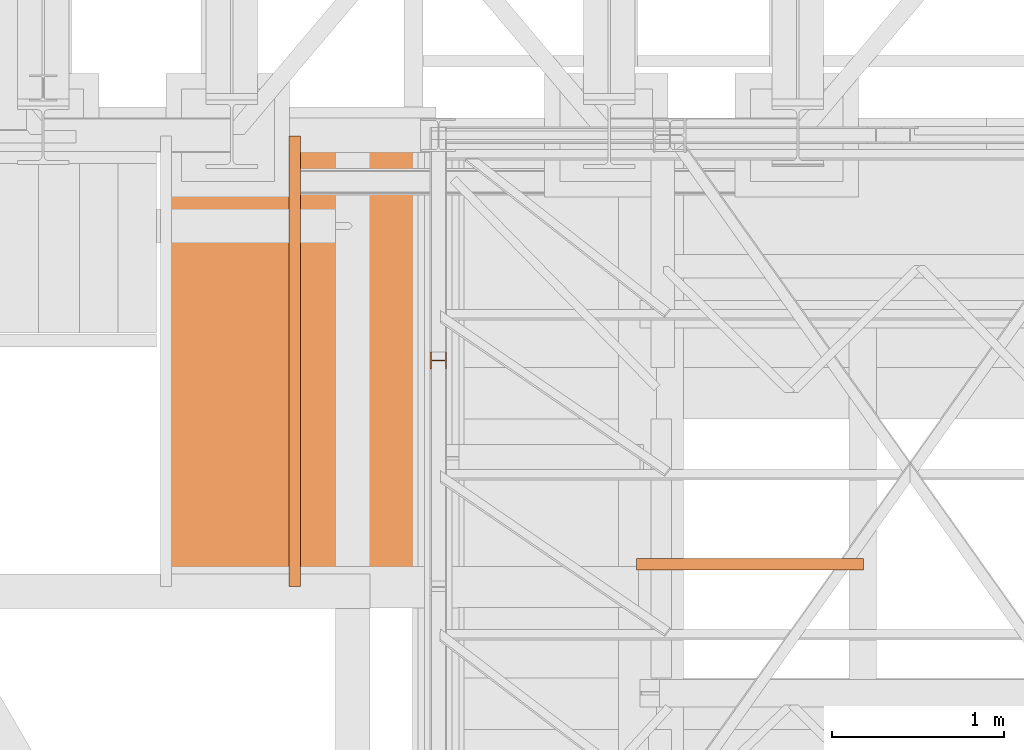
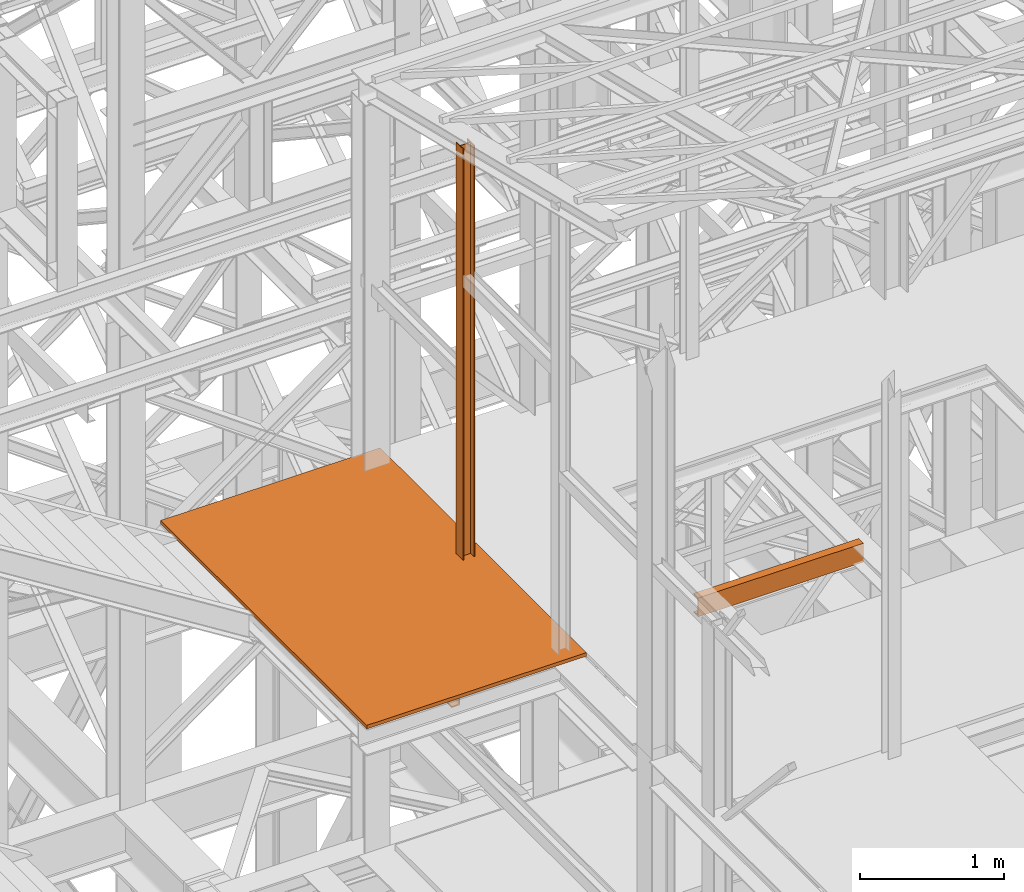
# One storey, part 29 of 208: 4 proxies.
"""IFC2X3 building model written with IfcOpenShell, lengths in millimetres."""

from ifc_helpers import new_model, entity, si_unit, converted_unit, frame, origin, origin_with_axes, place, context, subcontext, project, spatial, faceted_brep, element, save


model = new_model("IFC2X3")

# Units and contexts
model_context = context("Model", 3, precision=1e-05, world=origin())
plan_context = context("Plan", 3, precision=1e-05, world=origin())
body_context = subcontext(model_context, "Body", "Model", "MODEL_VIEW")
ifc_project = project(units=[si_unit("LENGTHUNIT", "METRE", prefix="MILLI"), converted_unit("PLANEANGLEUNIT", "DEGREE", entity("IfcPlaneAngleMeasure", 0.0174532925199433), si_unit("PLANEANGLEUNIT", "RADIAN"), dimensions=[0, 0, 0, 0, 0, 0, 0]), si_unit("AREAUNIT", "SQUARE_METRE"), si_unit("VOLUMEUNIT", "CUBIC_METRE")], contexts=[model_context, plan_context])

# Building, storey
building_placement = place(None, origin())
building = spatial("IfcBuilding", under=ifc_project, at=building_placement, CompositionType="COMPLEX")
storey_placement = place(building_placement, origin_with_axes())
storey = spatial("IfcBuildingStorey", under=building, at=storey_placement, Name="Geschoss", CompositionType="ELEMENT")

# Proxies
proxy_1_placement = place(storey_placement, frame((1150.25496814422, -18626.96003193789, 8484.990002086155), z_axis=(0.0, 0.0, 1.0), x_axis=(1.0, 0.0, 0.0)))
element("IfcBuildingElementProxy", 1, at=proxy_1_placement, inside=storey, context=body_context, shape_type="Brep", body=[
    faceted_brep([(8.009999999999991, 0.01000000000203727, 3504.259992333347), (0.009999999999990905, 0.01000000000203727, 3504.259992333347), (0.009999999999990905, 100.010000000002, 3504.259992333347), (8.009999999999991, 100.010000000002, 3504.259992333347), (8.009999999999991, 52.51000000000204, 3504.259992333347), (88.00999999999999, 52.51000000000204, 3504.259992333347), (88.00999999999999, 100.010000000002, 3504.259992333347), (96.00999999999999, 100.010000000002, 3504.259992333347), (96.00999999999999, 0.01000000000203727, 3504.259992333347), (88.00999999999999, 0.01000000000203727, 3504.259992333347), (88.00999999999999, 47.51000000000204, 3504.259992333347), (8.009999999999991, 47.51000000000204, 3504.259992333347), (0.009999999999990905, 0.01000000000203727, 3504.259992333347), (8.009999999999991, 0.01000000000203727, 3504.259992333347), (8.009999999999991, 0.01000000000203727, 0.01000000000021828), (0.009999999999990905, 0.01000000000203727, 0.01000000000021828), (0.009999999999990905, 100.010000000002, 3504.259992333347), (0.009999999999990905, 0.01000000000203727, 3504.259992333347), (0.009999999999990905, 0.01000000000203727, 0.01000000000021828), (0.009999999999990905, 100.0100000000057, 0.01000000000021828), (8.009999999999991, 100.010000000002, 3504.259992333347), (0.009999999999990905, 100.010000000002, 3504.259992333347), (0.009999999999990905, 100.0100000000057, 0.01000000000021828), (8.009999999999991, 100.0100000000057, 0.01000000000021828), (8.009999999999991, 52.51000000000204, 3504.259992333347), (8.009999999999991, 100.010000000002, 3504.259992333347), (8.009999999999991, 100.0100000000057, 0.01000000000021828), (8.009999999999991, 52.51000000000568, 0.01000000000021828), (88.00999999999999, 52.51000000000204, 3504.259992333347), (8.009999999999991, 52.51000000000204, 3504.259992333347), (8.009999999999991, 52.51000000000568, 0.01000000000021828), (88.00999999999999, 52.51000000000568, 0.01000000000021828), (88.00999999999999, 100.010000000002, 3504.259992333347), (88.00999999999999, 52.51000000000204, 3504.259992333347), (88.00999999999999, 52.51000000000568, 0.01000000000021828), (88.00999999999999, 100.0100000000057, 0.01000000000021828), (96.00999999999999, 100.010000000002, 3504.259992333347), (88.00999999999999, 100.010000000002, 3504.259992333347), (88.00999999999999, 100.0100000000057, 0.01000000000021828), (96.00999999999999, 100.0100000000057, 0.01000000000021828), (96.00999999999999, 0.01000000000203727, 3504.259992333347), (96.00999999999999, 100.010000000002, 3504.259992333347), (96.00999999999999, 100.0100000000057, 0.01000000000021828), (96.00999999999999, 0.01000000000203727, 0.01000000000021828), (88.00999999999999, 0.01000000000203727, 3504.259992333347), (96.00999999999999, 0.01000000000203727, 3504.259992333347), (96.00999999999999, 0.01000000000203727, 0.01000000000021828), (88.00999999999999, 0.01000000000203727, 0.01000000000021828), (88.00999999999999, 47.51000000000204, 3504.259992333347), (88.00999999999999, 0.01000000000203727, 3504.259992333347), (88.00999999999999, 0.01000000000203727, 0.01000000000021828), (88.00999999999999, 47.51000000000568, 0.01000000000021828), (8.009999999999991, 47.51000000000204, 3504.259992333347), (88.00999999999999, 47.51000000000204, 3504.259992333347), (88.00999999999999, 47.51000000000568, 0.01000000000021828), (8.009999999999991, 47.51000000000568, 0.01000000000021828), (8.009999999999991, 0.01000000000203727, 3504.259992333347), (8.009999999999991, 47.51000000000204, 3504.259992333347), (8.009999999999991, 47.51000000000568, 0.01000000000021828), (8.009999999999991, 0.01000000000203727, 0.01000000000021828), (8.009999999999991, 0.01000000000203727, 0.01000000000021828), (8.009999999999991, 47.51000000000568, 0.01000000000021828), (88.00999999999999, 47.51000000000568, 0.01000000000021828), (88.00999999999999, 0.01000000000203727, 0.01000000000021828), (96.00999999999999, 0.01000000000203727, 0.01000000000021828), (96.00999999999999, 100.0100000000057, 0.01000000000021828), (88.00999999999999, 100.0100000000057, 0.01000000000021828), (88.00999999999999, 52.51000000000568, 0.01000000000021828), (8.009999999999991, 52.51000000000568, 0.01000000000021828), (8.009999999999991, 100.0100000000057, 0.01000000000021828), (0.009999999999990905, 100.0100000000057, 0.01000000000021828), (0.009999999999990905, 0.01000000000203727, 0.01000000000021828)], [[[0, 1, 2, 3, 4, 5, 6, 7, 8, 9, 10, 11]], [[12, 13, 14, 15]], [[16, 17, 18, 19]], [[20, 21, 22, 23]], [[24, 25, 26, 27]], [[28, 29, 30, 31]], [[32, 33, 34, 35]], [[36, 37, 38, 39]], [[40, 41, 42, 43]], [[44, 45, 46, 47]], [[48, 49, 50, 51]], [[52, 53, 54, 55]], [[56, 57, 58, 59]], [[60, 61, 62, 63, 64, 65, 66, 67, 68, 69, 70, 71]]], orient=[[False], [False], [False], [False], [False], [False], [False], [False], [False], [False], [False], [False], [False], [False]]),
])
proxy_2_placement = place(storey_placement, frame((328.2096127045281, -19894.59359431297, 8324.990002086155), z_axis=(0.0, 0.0, 1.0), x_axis=(1.0, 0.0, 0.0)))
element("IfcBuildingElementProxy", 2, at=proxy_2_placement, inside=storey, context=body_context, shape_type="Brep", body=[
    faceted_brep([(65.00999999999999, 2627.529208944845, 160.0100000000002), (65.00999999999999, 0.00999999999839929, 160.0100000000002), (0.009999999999990905, 0.00999999999839929, 160.0100000000002), (0.009999999999990905, 2627.529208944845, 160.0100000000002), (0.009999999999990905, 2627.529208944845, 160.0100000000002), (0.009999999999990905, 0.00999999999839929, 160.0100000000002), (0.009999999999990905, 0.00999999999839929, 156.8875719297539), (0.009999999999990905, 2627.529208944845, 156.8875719297539), (0.009999999999990905, 2627.529208944845, 156.8875719297539), (0.009999999999990905, 0.00999999999839929, 156.8875719297539), (0.2527365771727546, 0.00999999999839929, 155.2717110918293), (0.2527365771727546, 2627.529208944845, 155.2717110918293), (0.2527365771727546, 2627.529208944845, 155.2717110918293), (0.2527365771727546, 0.00999999999839929, 155.2717110918293), (0.9594677141446937, 0.00999999999839929, 153.7984655565542), (0.9594677141446937, 2627.529208944845, 153.7984655565542), (0.9594677141446937, 2627.529208944845, 153.7984655565542), (0.9594677141446937, 0.00999999999839929, 153.7984655565542), (2.067848361531787, 0.00999999999839929, 152.5978732961266), (2.067848361531787, 2627.529208944845, 152.5978732961266), (2.067848361531787, 2627.529208944845, 152.5978732961266), (2.067848361531787, 0.00999999999839929, 152.5978732961266), (3.480043588516992, 0.00999999999839929, 151.7759086082897), (3.480043588516992, 2627.529208944845, 151.7759086082897), (3.480043588516992, 2627.529208944845, 151.7759086082897), (3.480043588516992, 0.00999999999839929, 151.7759086082897), (5.07140127744583, 0.00999999999839929, 151.4050878978051), (5.07140127744583, 2627.529208944845, 151.4050878978051), (5.07140127744583, 2627.529208944845, 151.4050878978051), (5.07140127744583, 0.00999999999839929, 151.4050878978051), (47.84732483397033, 0.00999999999839929, 147.9830140132835), (47.84732483397033, 2627.529208944845, 147.9830140132835), (47.84732483397033, 2627.529208944845, 147.9830140132835), (47.84732483397033, 0.00999999999839929, 147.9830140132835), (50.81159179199108, 0.00999999999839929, 147.318026761528), (50.81159179199108, 2627.529208944845, 147.318026761528), (50.81159179199108, 2627.529208944845, 147.318026761528), (50.81159179199108, 0.00999999999839929, 147.318026761528), (53.58138040071367, 0.00999999999839929, 145.7058782528511), (53.58138040071367, 2627.529208944845, 145.7058782528511), (53.58138040071367, 2627.529208944845, 145.7058782528511), (53.58138040071367, 0.00999999999839929, 145.7058782528511), (55.69737981845333, 0.00999999999839929, 143.4138384829421), (55.69737981845333, 2627.529208944845, 143.4138384829421), (55.69737981845333, 2627.529208944845, 143.4138384829421), (55.69737981845333, 0.00999999999839929, 143.4138384829421), (57.04659380721364, 0.00999999999839929, 140.6012788246917), (57.04659380721364, 2627.529208944845, 140.6012788246917), (57.04659380721364, 2627.529208944845, 140.6012788246917), (57.04659380721364, 0.00999999999839929, 140.6012788246917), (57.50999999999999, 0.00999999999839929, 137.5164535886543), (57.50999999999999, 2627.529208944845, 137.5164535886543), (57.50999999999999, 2627.529208944845, 137.5164535886543), (57.50999999999999, 0.00999999999839929, 137.5164535886543), (57.50999999999999, 0.00999999999839929, 22.503546411348), (57.50999999999999, 2627.529208944845, 22.503546411348), (57.50999999999999, 2627.529208944845, 22.503546411348), (57.50999999999999, 0.00999999999839929, 22.503546411348), (57.04659380721364, 0.00999999999839929, 19.41872117530875), (57.04659380721364, 2627.529208944845, 19.41872117530875), (57.04659380721364, 2627.529208944845, 19.41872117530875), (57.04659380721364, 0.00999999999839929, 19.41872117530875), (55.69737981845333, 0.00999999999839929, 16.60616151705835), (55.69737981845333, 2627.529208944845, 16.60616151705835), (55.69737981845333, 2627.529208944845, 16.60616151705835), (55.69737981845333, 0.00999999999839929, 16.60616151705835), (53.58138040071367, 0.00999999999839929, 14.31412174714933), (53.58138040071367, 2627.529208944845, 14.31412174714933), (53.58138040071367, 2627.529208944845, 14.31412174714933), (53.58138040071367, 0.00999999999839929, 14.31412174714933), (50.88537133101795, 0.00999999999839929, 12.74491643400688), (50.88537133101795, 2627.529208944845, 12.74491643400688), (50.88537133101795, 2627.529208944845, 12.74491643400688), (50.88537133101795, 0.00999999999839929, 12.74491643400688), (47.84732483397033, 0.00999999999839929, 12.03698598671872), (47.84732483397033, 2627.529208944845, 12.03698598671872), (47.84732483397033, 2627.529208944845, 12.03698598671872), (47.84732483397033, 0.00999999999839929, 12.03698598671872), (5.07140127744583, 0.00999999999839929, 8.614912102195376), (5.07140127744583, 2627.529208944845, 8.614912102195376), (5.07140127744583, 2627.529208944845, 8.614912102195376), (5.07140127744583, 0.00999999999839929, 8.614912102195376), (3.480043588516992, 0.00999999999839929, 8.244091391710754), (3.480043588516992, 2627.529208944845, 8.244091391710754), (3.480043588516992, 2627.529208944845, 8.244091391710754), (3.480043588516992, 0.00999999999839929, 8.244091391710754), (2.067848361531787, 0.00999999999839929, 7.422126703873801), (2.067848361531787, 2627.529208944845, 7.422126703873801), (2.067848361531787, 2627.529208944845, 7.422126703873801), (2.067848361531787, 0.00999999999839929, 7.422126703873801), (0.9594677141446937, 0.00999999999839929, 6.221534443446217), (0.9594677141446937, 2627.529208944845, 6.221534443446217), (0.9594677141446937, 2627.529208944845, 6.221534443446217), (0.9594677141446937, 0.00999999999839929, 6.221534443446217), (0.2527365771727546, 0.00999999999839929, 4.748288908172981), (0.2527365771727546, 2627.529208944845, 4.748288908172981), (0.2527365771727546, 2627.529208944845, 4.748288908172981), (0.2527365771727546, 0.00999999999839929, 4.748288908172981), (0.009999999999990905, 0.00999999999839929, 0.01000000000021828), (0.009999999999990905, 2627.529208944845, 0.01000000000021828), (0.009999999999990905, 2627.529208944845, 0.01000000000021828), (0.009999999999990905, 0.00999999999839929, 0.01000000000021828), (65.00999999999999, 0.00999999999839929, 0.01000000000021828), (65.00999999999999, 2627.529208944845, 0.01000000000021828), (65.00999999999999, 2627.529208944845, 0.01000000000021828), (65.00999999999999, 0.00999999999839929, 0.01000000000021828), (65.00999999999999, 0.00999999999839929, 160.0100000000002), (65.00999999999999, 2627.529208944845, 160.0100000000002), (65.00999999999999, 2627.529208944845, 160.0100000000002), (0.009999999999990905, 2627.529208944845, 160.0100000000002), (0.009999999999990905, 2627.529208944845, 156.8875719297539), (0.2527365771727546, 2627.529208944845, 155.2717110918293), (0.9594677141446937, 2627.529208944845, 153.7984655565542), (2.067848361531787, 2627.529208944845, 152.5978732961266), (3.480043588516992, 2627.529208944845, 151.7759086082897), (5.07140127744583, 2627.529208944845, 151.4050878978051), (47.84732483397033, 2627.529208944845, 147.9830140132835), (50.81159179199108, 2627.529208944845, 147.318026761528), (53.58138040071367, 2627.529208944845, 145.7058782528511), (55.69737981845333, 2627.529208944845, 143.4138384829421), (57.04659380721364, 2627.529208944845, 140.6012788246917), (57.50999999999999, 2627.529208944845, 137.5164535886543), (57.50999999999999, 2627.529208944845, 22.503546411348), (57.04659380721364, 2627.529208944845, 19.41872117530875), (55.69737981845333, 2627.529208944845, 16.60616151705835), (53.58138040071367, 2627.529208944845, 14.31412174714933), (50.88537133101795, 2627.529208944845, 12.74491643400688), (47.84732483397033, 2627.529208944845, 12.03698598671872), (5.07140127744583, 2627.529208944845, 8.614912102195376), (3.480043588516992, 2627.529208944845, 8.244091391710754), (2.067848361531787, 2627.529208944845, 7.422126703873801), (0.9594677141446937, 2627.529208944845, 6.221534443446217), (0.2527365771727546, 2627.529208944845, 4.748288908172981), (0.009999999999990905, 2627.529208944845, 0.01000000000021828), (65.00999999999999, 2627.529208944845, 0.01000000000021828), (65.00999999999999, 0.00999999999839929, 160.0100000000002), (65.00999999999999, 0.00999999999839929, 0.01000000000021828), (0.009999999999990905, 0.00999999999839929, 0.01000000000021828), (0.2527365771727546, 0.00999999999839929, 4.748288908172981), (0.9594677141446937, 0.00999999999839929, 6.221534443446217), (2.067848361531787, 0.00999999999839929, 7.422126703873801), (3.480043588516992, 0.00999999999839929, 8.244091391710754), (5.07140127744583, 0.00999999999839929, 8.614912102195376), (47.84732483397033, 0.00999999999839929, 12.03698598671872), (50.88537133101795, 0.00999999999839929, 12.74491643400688), (53.58138040071367, 0.00999999999839929, 14.31412174714933), (55.69737981845333, 0.00999999999839929, 16.60616151705835), (57.04659380721364, 0.00999999999839929, 19.41872117530875), (57.50999999999999, 0.00999999999839929, 22.503546411348), (57.50999999999999, 0.00999999999839929, 137.5164535886543), (57.04659380721364, 0.00999999999839929, 140.6012788246917), (55.69737981845333, 0.00999999999839929, 143.4138384829421), (53.58138040071367, 0.00999999999839929, 145.7058782528511), (50.81159179199108, 0.00999999999839929, 147.318026761528), (47.84732483397033, 0.00999999999839929, 147.9830140132835), (5.07140127744583, 0.00999999999839929, 151.4050878978051), (3.480043588516992, 0.00999999999839929, 151.7759086082897), (2.067848361531787, 0.00999999999839929, 152.5978732961266), (0.9594677141446937, 0.00999999999839929, 153.7984655565542), (0.2527365771727546, 0.00999999999839929, 155.2717110918293), (0.009999999999990905, 0.00999999999839929, 156.8875719297539), (0.009999999999990905, 0.00999999999839929, 160.0100000000002)], [[[0, 1, 2, 3]], [[4, 5, 6, 7]], [[8, 9, 10, 11]], [[12, 13, 14, 15]], [[16, 17, 18, 19]], [[20, 21, 22, 23]], [[24, 25, 26, 27]], [[28, 29, 30, 31]], [[32, 33, 34, 35]], [[36, 37, 38, 39]], [[40, 41, 42, 43]], [[44, 45, 46, 47]], [[48, 49, 50, 51]], [[52, 53, 54, 55]], [[56, 57, 58, 59]], [[60, 61, 62, 63]], [[64, 65, 66, 67]], [[68, 69, 70, 71]], [[72, 73, 74, 75]], [[76, 77, 78, 79]], [[80, 81, 82, 83]], [[84, 85, 86, 87]], [[88, 89, 90, 91]], [[92, 93, 94, 95]], [[96, 97, 98, 99]], [[100, 101, 102, 103]], [[104, 105, 106, 107]], [[108, 109, 110, 111, 112, 113, 114, 115, 116, 117, 118, 119, 120, 121, 122, 123, 124, 125, 126, 127, 128, 129, 130, 131, 132, 133, 134]], [[135, 136, 137, 138, 139, 140, 141, 142, 143, 144, 145, 146, 147, 148, 149, 150, 151, 152, 153, 154, 155, 156, 157, 158, 159, 160, 161]]], orient=[[False], [False], [False], [False], [False], [False], [False], [False], [False], [False], [False], [False], [False], [False], [False], [False], [False], [False], [False], [False], [False], [False], [False], [False], [False], [False], [False], [False], [False]]),
])
proxy_3_placement = place(storey_placement, frame((2354.37341277025, -19796.85029743702, 8324.990002086155), z_axis=(0.0, 0.0, 1.0), x_axis=(1.0, 0.0, 0.0)))
element("IfcBuildingElementProxy", 3, at=proxy_3_placement, inside=storey, context=body_context, shape_type="Brep", body=[
    faceted_brep([(1321.604753847863, 0.00999999999839929, 160.0100000000002), (0.01000000000021828, 0.00999999999839929, 160.0100000000002), (0.01000000000021828, 65.0099999999984, 160.0100000000002), (1321.604753847863, 65.0099999999984, 160.0100000000002), (1321.604753847863, 65.0099999999984, 160.0100000000002), (0.01000000000021828, 65.0099999999984, 160.0100000000002), (0.01000000000021828, 65.0099999999984, 156.8875719297539), (1321.604753847863, 65.0099999999984, 156.8875719297539), (1321.604753847863, 65.0099999999984, 156.8875719297539), (0.01000000000021828, 65.0099999999984, 156.8875719297539), (0.01000000000021828, 64.76726342282564, 155.2717110918293), (1321.604753847863, 64.76726342282564, 155.2717110918293), (1321.604753847863, 64.76726342282564, 155.2717110918293), (0.01000000000021828, 64.76726342282564, 155.2717110918293), (0.01000000000021828, 64.0605322858537, 153.7984655565542), (1321.604753847863, 64.0605322858537, 153.7984655565542), (1321.604753847863, 64.0605322858537, 153.7984655565542), (0.01000000000021828, 64.0605322858537, 153.7984655565542), (0.01000000000021828, 62.9521516384666, 152.5978732961266), (1321.604753847863, 62.9521516384666, 152.5978732961266), (1321.604753847863, 62.9521516384666, 152.5978732961266), (0.01000000000021828, 62.9521516384666, 152.5978732961266), (0.01000000000021828, 61.5399564114814, 151.7759086082897), (1321.604753847863, 61.5399564114814, 151.7759086082897), (1321.604753847863, 61.5399564114814, 151.7759086082897), (0.01000000000021828, 61.5399564114814, 151.7759086082897), (0.01000000000021828, 59.94859872255256, 151.4050878978051), (1321.604753847863, 59.94859872255256, 151.4050878978051), (1321.604753847863, 59.94859872255256, 151.4050878978051), (0.01000000000021828, 59.94859872255256, 151.4050878978051), (0.01000000000021828, 17.17267516602806, 147.9830140132835), (1321.604753847863, 17.17267516602806, 147.9830140132835), (1321.604753847863, 17.17267516602806, 147.9830140132835), (0.01000000000021828, 17.17267516602806, 147.9830140132835), (0.01000000000021828, 14.20840820800731, 147.318026761528), (1321.604753847863, 14.20840820800731, 147.318026761528), (1321.604753847863, 14.20840820800731, 147.318026761528), (0.01000000000021828, 14.20840820800731, 147.318026761528), (0.01000000000021828, 11.43861959928472, 145.7058782528511), (1321.604753847863, 11.43861959928472, 145.7058782528511), (1321.604753847863, 11.43861959928472, 145.7058782528511), (0.01000000000021828, 11.43861959928472, 145.7058782528511), (0.01000000000021828, 9.322620181545062, 143.4138384829421), (1321.604753847863, 9.322620181545062, 143.4138384829421), (1321.604753847863, 9.322620181545062, 143.4138384829421), (0.01000000000021828, 9.322620181545062, 143.4138384829421), (0.01000000000021828, 7.973406192784751, 140.6012788246917), (1321.604753847863, 7.973406192784751, 140.6012788246917), (1321.604753847863, 7.973406192784751, 140.6012788246917), (0.01000000000021828, 7.973406192784751, 140.6012788246917), (0.01000000000021828, 7.509999999998399, 137.5164535886543), (1321.604753847863, 7.509999999998399, 137.5164535886543), (1321.604753847863, 7.509999999998399, 137.5164535886543), (0.01000000000021828, 7.509999999998399, 137.5164535886543), (0.01000000000021828, 7.509999999998399, 22.503546411348), (1321.604753847863, 7.509999999998399, 22.503546411348), (1321.604753847863, 7.509999999998399, 22.503546411348), (0.01000000000021828, 7.509999999998399, 22.503546411348), (0.01000000000021828, 7.973406192784751, 19.41872117530875), (1321.604753847863, 7.973406192784751, 19.41872117530875), (1321.604753847863, 7.973406192784751, 19.41872117530875), (0.01000000000021828, 7.973406192784751, 19.41872117530875), (0.01000000000021828, 9.322620181545062, 16.60616151705835), (1321.604753847863, 9.322620181545062, 16.60616151705835), (1321.604753847863, 9.322620181545062, 16.60616151705835), (0.01000000000021828, 9.322620181545062, 16.60616151705835), (0.01000000000021828, 11.43861959928472, 14.31412174714933), (1321.604753847863, 11.43861959928472, 14.31412174714933), (1321.604753847863, 11.43861959928472, 14.31412174714933), (0.01000000000021828, 11.43861959928472, 14.31412174714933), (0.01000000000021828, 14.13462866898044, 12.74491643400688), (1321.604753847863, 14.13462866898044, 12.74491643400688), (1321.604753847863, 14.13462866898044, 12.74491643400688), (0.01000000000021828, 14.13462866898044, 12.74491643400688), (0.01000000000021828, 17.17267516602806, 12.03698598671872), (1321.604753847863, 17.17267516602806, 12.03698598671872), (1321.604753847863, 17.17267516602806, 12.03698598671872), (0.01000000000021828, 17.17267516602806, 12.03698598671872), (0.01000000000021828, 59.94859872255256, 8.614912102195376), (1321.604753847863, 59.94859872255256, 8.614912102195376), (1321.604753847863, 59.94859872255256, 8.614912102195376), (0.01000000000021828, 59.94859872255256, 8.614912102195376), (0.01000000000021828, 61.5399564114814, 8.244091391710754), (1321.604753847863, 61.5399564114814, 8.244091391710754), (1321.604753847863, 61.5399564114814, 8.244091391710754), (0.01000000000021828, 61.5399564114814, 8.244091391710754), (0.01000000000021828, 62.9521516384666, 7.422126703873801), (1321.604753847863, 62.9521516384666, 7.422126703873801), (1321.604753847863, 62.9521516384666, 7.422126703873801), (0.01000000000021828, 62.9521516384666, 7.422126703873801), (0.01000000000021828, 64.0605322858537, 6.221534443446217), (1321.604753847863, 64.0605322858537, 6.221534443446217), (1321.604753847863, 64.0605322858537, 6.221534443446217), (0.01000000000021828, 64.0605322858537, 6.221534443446217), (0.01000000000021828, 64.76726342282564, 4.748288908172981), (1321.604753847863, 64.76726342282564, 4.748288908172981), (1321.604753847863, 64.76726342282564, 4.748288908172981), (0.01000000000021828, 64.76726342282564, 4.748288908172981), (0.01000000000021828, 65.0099999999984, 0.01000000000021828), (1321.604753847863, 65.0099999999984, 0.01000000000021828), (1321.604753847863, 65.0099999999984, 0.01000000000021828), (0.01000000000021828, 65.0099999999984, 0.01000000000021828), (0.01000000000021828, 0.00999999999839929, 0.01000000000021828), (1321.604753847863, 0.00999999999839929, 0.01000000000021828), (1321.604753847863, 0.00999999999839929, 0.01000000000021828), (0.01000000000021828, 0.00999999999839929, 0.01000000000021828), (0.01000000000021828, 0.00999999999839929, 160.0100000000002), (1321.604753847863, 0.00999999999839929, 160.0100000000002), (1321.604753847863, 0.00999999999839929, 160.0100000000002), (1321.604753847863, 65.0099999999984, 160.0100000000002), (1321.604753847863, 65.0099999999984, 156.8875719297539), (1321.604753847863, 64.76726342282564, 155.2717110918293), (1321.604753847863, 64.0605322858537, 153.7984655565542), (1321.604753847863, 62.9521516384666, 152.5978732961266), (1321.604753847863, 61.5399564114814, 151.7759086082897), (1321.604753847863, 59.94859872255256, 151.4050878978051), (1321.604753847863, 17.17267516602806, 147.9830140132835), (1321.604753847863, 14.20840820800731, 147.318026761528), (1321.604753847863, 11.43861959928472, 145.7058782528511), (1321.604753847863, 9.322620181545062, 143.4138384829421), (1321.604753847863, 7.973406192784751, 140.6012788246917), (1321.604753847863, 7.509999999998399, 137.5164535886543), (1321.604753847863, 7.509999999998399, 22.503546411348), (1321.604753847863, 7.973406192784751, 19.41872117530875), (1321.604753847863, 9.322620181545062, 16.60616151705835), (1321.604753847863, 11.43861959928472, 14.31412174714933), (1321.604753847863, 14.13462866898044, 12.74491643400688), (1321.604753847863, 17.17267516602806, 12.03698598671872), (1321.604753847863, 59.94859872255256, 8.614912102195376), (1321.604753847863, 61.5399564114814, 8.244091391710754), (1321.604753847863, 62.9521516384666, 7.422126703873801), (1321.604753847863, 64.0605322858537, 6.221534443446217), (1321.604753847863, 64.76726342282564, 4.748288908172981), (1321.604753847863, 65.0099999999984, 0.01000000000021828), (1321.604753847863, 0.00999999999839929, 0.01000000000021828), (0.01000000000021828, 0.00999999999839929, 160.0100000000002), (0.01000000000021828, 0.00999999999839929, 0.01000000000021828), (0.01000000000021828, 65.0099999999984, 0.01000000000021828), (0.01000000000021828, 64.76726342282564, 4.748288908172981), (0.01000000000021828, 64.0605322858537, 6.221534443446217), (0.01000000000021828, 62.9521516384666, 7.422126703873801), (0.01000000000021828, 61.5399564114814, 8.244091391710754), (0.01000000000021828, 59.94859872255256, 8.614912102195376), (0.01000000000021828, 17.17267516602806, 12.03698598671872), (0.01000000000021828, 14.13462866898044, 12.74491643400688), (0.01000000000021828, 11.43861959928472, 14.31412174714933), (0.01000000000021828, 9.322620181545062, 16.60616151705835), (0.01000000000021828, 7.973406192784751, 19.41872117530875), (0.01000000000021828, 7.509999999998399, 22.503546411348), (0.01000000000021828, 7.509999999998399, 137.5164535886543), (0.01000000000021828, 7.973406192784751, 140.6012788246917), (0.01000000000021828, 9.322620181545062, 143.4138384829421), (0.01000000000021828, 11.43861959928472, 145.7058782528511), (0.01000000000021828, 14.20840820800731, 147.318026761528), (0.01000000000021828, 17.17267516602806, 147.9830140132835), (0.01000000000021828, 59.94859872255256, 151.4050878978051), (0.01000000000021828, 61.5399564114814, 151.7759086082897), (0.01000000000021828, 62.9521516384666, 152.5978732961266), (0.01000000000021828, 64.0605322858537, 153.7984655565542), (0.01000000000021828, 64.76726342282564, 155.2717110918293), (0.01000000000021828, 65.0099999999984, 156.8875719297539), (0.01000000000021828, 65.0099999999984, 160.0100000000002)], [[[0, 1, 2, 3]], [[4, 5, 6, 7]], [[8, 9, 10, 11]], [[12, 13, 14, 15]], [[16, 17, 18, 19]], [[20, 21, 22, 23]], [[24, 25, 26, 27]], [[28, 29, 30, 31]], [[32, 33, 34, 35]], [[36, 37, 38, 39]], [[40, 41, 42, 43]], [[44, 45, 46, 47]], [[48, 49, 50, 51]], [[52, 53, 54, 55]], [[56, 57, 58, 59]], [[60, 61, 62, 63]], [[64, 65, 66, 67]], [[68, 69, 70, 71]], [[72, 73, 74, 75]], [[76, 77, 78, 79]], [[80, 81, 82, 83]], [[84, 85, 86, 87]], [[88, 89, 90, 91]], [[92, 93, 94, 95]], [[96, 97, 98, 99]], [[100, 101, 102, 103]], [[104, 105, 106, 107]], [[108, 109, 110, 111, 112, 113, 114, 115, 116, 117, 118, 119, 120, 121, 122, 123, 124, 125, 126, 127, 128, 129, 130, 131, 132, 133, 134]], [[135, 136, 137, 138, 139, 140, 141, 142, 143, 144, 145, 146, 147, 148, 149, 150, 151, 152, 153, 154, 155, 156, 157, 158, 159, 160, 161]]], orient=[[False], [False], [False], [False], [False], [False], [False], [False], [False], [False], [False], [False], [False], [False], [False], [False], [False], [False], [False], [False], [False], [False], [False], [False], [False], [False], [False], [False], [False]]),
])
proxy_4_placement = place(storey_placement, frame((-421.7450362397046, -20018.66159598975, 8484.990002086157), z_axis=(0.0, 0.0, 1.0), x_axis=(1.0, 0.0, 0.0)))
element("IfcBuildingElementProxy", 4, at=proxy_4_placement, inside=storey, context=body_context, shape_type="Brep", body=[
    faceted_brep([(0.009999999999990905, 0.00999999999839929, 0.01000000000021828), (1755.010006258486, 0.00999999999839929, 0.01000000000021828), (1755.010006258486, 2856.097210621621, 0.01000000000021828), (0.009999999999990905, 2856.097210621621, 0.01000000000021828), (1755.010006258486, 0.00999999999839929, 30.01000000000022), (0.009999999999990905, 0.00999999999839929, 30.01000000000022), (0.009999999999990905, 2856.097210621621, 30.01000000000022), (1755.010006258486, 2856.097210621621, 30.01000000000022), (1755.010006258486, 0.00999999999839929, 0.01000000000021828), (0.009999999999990905, 0.00999999999839929, 0.01000000000021828), (0.009999999999990905, 0.00999999999839929, 30.01000000000022), (1755.010006258486, 0.00999999999839929, 30.01000000000022), (1755.010006258486, 2856.097210621621, 0.01000000000021828), (1755.010006258486, 0.00999999999839929, 0.01000000000021828), (1755.010006258486, 0.00999999999839929, 30.01000000000022), (1755.010006258486, 2856.097210621621, 30.01000000000022), (0.009999999999990905, 2856.097210621621, 0.01000000000021828), (1755.010006258486, 2856.097210621621, 0.01000000000021828), (1755.010006258486, 2856.097210621621, 30.01000000000022), (0.009999999999990905, 2856.097210621621, 30.01000000000022), (0.009999999999990905, 0.00999999999839929, 0.01000000000021828), (0.009999999999990905, 2856.097210621621, 0.01000000000021828), (0.009999999999990905, 2856.097210621621, 30.01000000000022), (0.009999999999990905, 0.00999999999839929, 30.01000000000022)], [[[0, 1, 2, 3]], [[4, 5, 6, 7]], [[8, 9, 10, 11]], [[12, 13, 14, 15]], [[16, 17, 18, 19]], [[20, 21, 22, 23]]], orient=[[False], [False], [False], [False], [False], [False]]),
])

save(model, "model.ifc")
